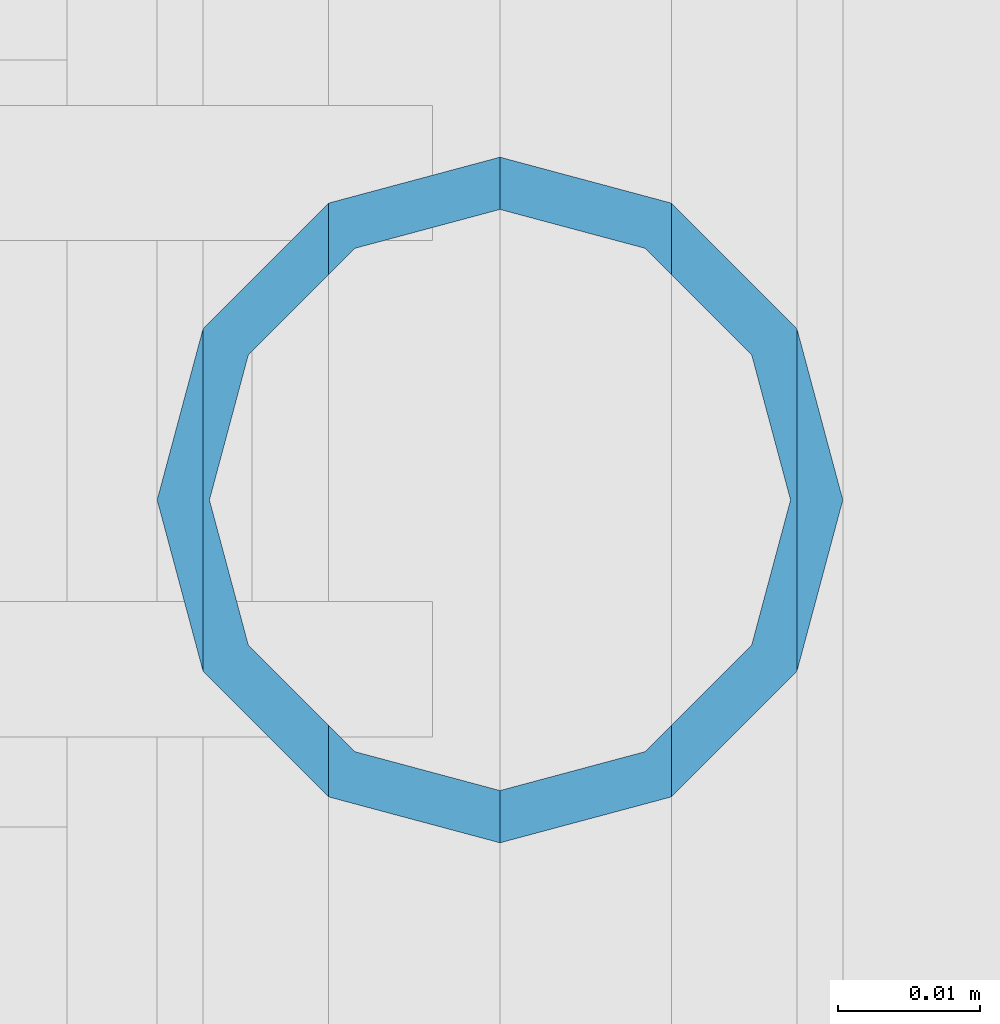
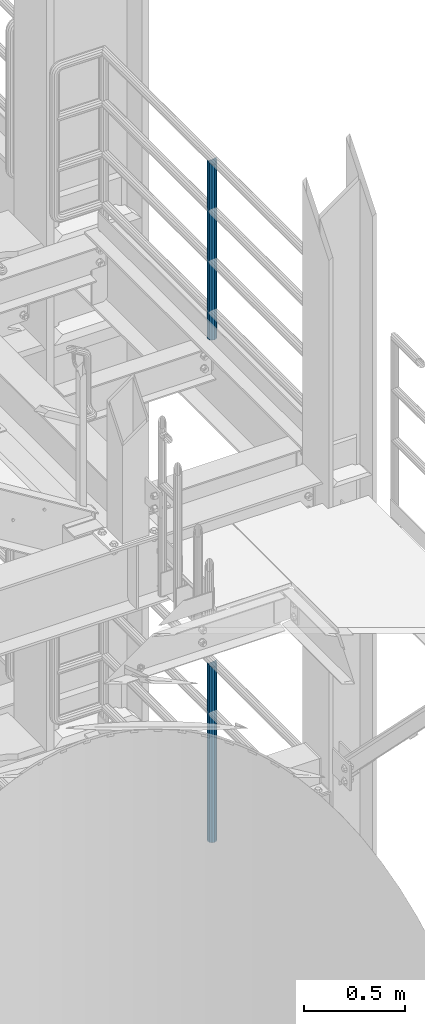
# One storey, part 660 of 1876: 2 columns, 2 elements without a shape of their own.
"""IFC2X3 building model written with IfcOpenShell, lengths in millimetres."""

from ifc_helpers import new_model, si_unit, frame, origin_with_axes, place, context, subcontext, project, spatial, faceted_brep, material, type_object, element, aggregate, save


model = new_model("IFC2X3")

# Units and contexts
model_context = context("Model", 3, precision=1e-05, world=origin_with_axes())
body_context = subcontext(model_context, "Body", "Model", "MODEL_VIEW")
ifc_project = project(units=[si_unit("LENGTHUNIT", "METRE", prefix="MILLI"), si_unit("AREAUNIT", "SQUARE_METRE"), si_unit("VOLUMEUNIT", "CUBIC_METRE"), si_unit("MASSUNIT", "GRAM", prefix="KILO"), si_unit("TIMEUNIT", "SECOND"), si_unit("PLANEANGLEUNIT", "RADIAN"), si_unit("SOLIDANGLEUNIT", "STERADIAN"), si_unit("THERMODYNAMICTEMPERATUREUNIT", "DEGREE_CELSIUS"), si_unit("LUMINOUSINTENSITYUNIT", "LUMEN")], contexts=[model_context])

# Site, building, storey
site_placement = place(None, origin_with_axes())
site = spatial("IfcSite", under=ifc_project, at=site_placement, CompositionType="ELEMENT")
building_placement = place(site_placement, origin_with_axes())
building = spatial("IfcBuilding", under=site, at=building_placement, Name="Undefined", CompositionType="ELEMENT")
storey_placement = place(building_placement, origin_with_axes())
storey = spatial("IfcBuildingStorey", under=building, at=storey_placement, Name="Undefined", CompositionType="ELEMENT", Elevation=0.0)

# Assembly, column
assembly_1_placement = place(storey_placement, origin_with_axes())
assembly_1 = element("IfcElementAssembly", 1, at=assembly_1_placement, inside=storey, Name="RAIL", AssemblyPlace="NOTDEFINED", PredefinedType="RIGID_FRAME")
ifc_material = material()
column_type = type_object("IfcColumnType", Name="PIPE1-1/2SCH40", PredefinedType="NOTDEFINED")
column_1_placement = place(assembly_1_placement, frame((7620.00000000001, -5857.08125, 8153.4), z_axis=(0.0, 1.0, 0.0), x_axis=(0.0, 0.0, 1.0)))
column_1 = element("IfcColumn", 2, at=column_1_placement, type_object=column_type, material=ifc_material, Name="POST", ObjectType="PIPE1-1/2SCH40", context=body_context, shape_type="Brep", body=[
    faceted_brep([(1055.42780700668, -12.0650000000001, 20.8971929933186), (1055.42780700668, -12.0650000000001, 15.8661214311805), (1054.93437856882, -10.2235000000001, 17.7076214311801), (1052.195, 0.0, 20.4470000000001), (1052.195, 0.0, 24.1300000000001), (1054.93437856882, 10.2235000000001, 17.7076214311801), (1055.42780700668, 12.0650000000001, 15.8661214311805), (1055.42780700668, 12.0650000000001, 20.8971929933186), (1076.325, 24.1300000000001, 0.0), (1064.26, 20.8971929933184, 12.0649999999996), (1064.25999999999, 20.8971929933186, -12.0649999999996), (1061.07042843786, 17.7076214311803, 10.2235000000001), (1063.80980700668, 20.4469999999999, 0.0), (1061.07042843786, 17.7076214311803, -10.2235000000001), (1055.42780700668, 12.0650000000001, -15.8661214311805), (1055.42780700667, 12.0649999999996, -20.8971929933186), (1054.93437856882, 10.2235000000001, -17.7076214311801), (1052.195, 0.0, -20.4470000000001), (1052.19499999999, 0.0, -24.1300000000001), (1055.42780700668, -12.0650000000001, -15.8661214311805), (1055.42780700667, -12.0649999999996, -20.8971929933186), (1054.93437856882, -10.2235000000001, -17.7076214311801), (1076.325, -24.1300000000001, 0.0), (1064.25999999999, -20.8971929933186, -12.0649999999996), (1064.26, -20.8971929933184, 12.0649999999996), (1061.07042843786, -17.7076214311803, -10.2235000000001), (1063.80980700668, -20.4469999999999, 0.0), (1061.07042843786, -17.7076214311803, 10.2235000000001), (0.0, -20.8971929933184, -12.0649999999996), (0.0, -12.0650000000001, -20.8971929933186), (-1.45519152283669e-11, 0.0, -24.130000000001), (0.0, 12.0650000000001, -20.8971929933186), (0.0, 20.8971929933184, -12.0649999999996), (0.0, 24.1299999999992, 0.0), (0.0, 20.8971929933184, 12.0649999999996), (0.0, 12.0650000000001, 20.8971929933186), (-1.45519152283669e-11, 0.0, 24.130000000001), (0.0, -12.0650000000001, 20.8971929933186), (0.0, -20.8971929933184, 12.0649999999996), (0.0, -24.1299999999992, 0.0), (0.0, -17.7076214311803, -10.2235000000001), (0.0, -10.2235000000001, -17.7076214311801), (-1.45519152283669e-11, 0.0, -20.4470000000001), (0.0, 10.2235000000001, -17.7076214311801), (0.0, 17.7076214311803, -10.2235000000001), (0.0, 20.4469999999999, 0.0), (0.0, 17.7076214311803, 10.2235000000001), (0.0, 10.2235000000001, 17.7076214311801), (-1.45519152283669e-11, 0.0, 20.4470000000001), (0.0, -10.2235000000001, 17.7076214311801), (0.0, -17.7076214311803, 10.2235000000001), (0.0, -20.4469999999999, 0.0)], [[[0, 1, 2, 3, 4]], [[4, 3, 5, 6, 7]], [[8, 9, 10]], [[7, 6, 11, 12, 13, 14, 15, 10, 9]], [[16, 17, 18, 15, 14]], [[19, 20, 18, 17, 21]], [[22, 23, 24]], [[24, 23, 20, 19, 25, 26, 27, 1, 0]], [[28, 29, 20, 23]], [[29, 30, 18, 20]], [[30, 31, 15, 18]], [[31, 32, 10, 15]], [[32, 33, 8, 10]], [[33, 34, 9, 8]], [[34, 35, 7, 9]], [[35, 36, 4, 7]], [[36, 37, 0, 4]], [[37, 38, 24, 0]], [[38, 39, 22, 24]], [[39, 28, 23, 22]], [[38, 37, 36, 35, 34, 33, 32, 31, 30, 29, 28, 39], [40, 41, 42, 43, 44, 45, 46, 47, 48, 49, 50, 51]], [[40, 51, 26, 25]], [[21, 41, 40, 25, 19]], [[42, 41, 21, 17]], [[43, 42, 17, 16]], [[44, 43, 16, 14, 13]], [[45, 44, 13, 12]], [[46, 45, 12, 11]], [[5, 47, 46, 11, 6]], [[48, 47, 5, 3]], [[49, 48, 3, 2]], [[50, 49, 2, 1, 27]], [[51, 50, 27, 26]]]),
])
aggregate(assembly_1, [column_1])

assembly_2_placement = place(storey_placement, origin_with_axes())
assembly_2 = element("IfcElementAssembly", 3, at=assembly_2_placement, inside=storey, Name="RAIL", AssemblyPlace="NOTDEFINED", PredefinedType="RIGID_FRAME")
column_2_placement = place(assembly_2_placement, frame((7620.00000000001, -5857.08125, 5130.80000110474), z_axis=(0.0, 1.0, 0.0), x_axis=(0.0, 0.0, 1.0)))
column_2 = element("IfcColumn", 4, at=column_2_placement, type_object=column_type, material=ifc_material, Name="POST", ObjectType="PIPE1-1/2SCH40", context=body_context, shape_type="Brep", body=[
    faceted_brep([(1055.42780700668, -12.0650000000001, 20.8971929933186), (1055.42780700668, -12.0650000000001, 15.8661214311805), (1054.93437856882, -10.2235000000001, 17.7076214311801), (1052.195, 0.0, 20.4470000000001), (1052.195, 0.0, 24.1300000000001), (1054.93437856882, 10.2235000000001, 17.7076214311801), (1055.42780700668, 12.0650000000001, 15.8661214311805), (1055.42780700668, 12.0650000000001, 20.8971929933186), (1076.325, 24.1300000000001, 0.0), (1064.26, 20.8971929933184, 12.0649999999996), (1064.25999999999, 20.8971929933186, -12.0649999999996), (1061.07042843786, 17.7076214311803, 10.2235000000001), (1063.80980700668, 20.4469999999999, 0.0), (1061.07042843786, 17.7076214311803, -10.2235000000001), (1055.42780700668, 12.0650000000001, -15.8661214311805), (1055.42780700667, 12.0649999999996, -20.8971929933186), (1054.93437856882, 10.2235000000001, -17.7076214311801), (1052.195, 0.0, -20.4470000000001), (1052.19499999999, 0.0, -24.1300000000001), (1055.42780700668, -12.0650000000001, -15.8661214311805), (1055.42780700667, -12.0649999999996, -20.8971929933186), (1054.93437856882, -10.2235000000001, -17.7076214311801), (1076.325, -24.1300000000001, 0.0), (1064.25999999999, -20.8971929933186, -12.0649999999996), (1064.26, -20.8971929933184, 12.0649999999996), (1061.07042843786, -17.7076214311803, -10.2235000000001), (1063.80980700668, -20.4469999999999, 0.0), (1061.07042843786, -17.7076214311803, 10.2235000000001), (0.0, -20.8971929933184, -12.0649999999996), (0.0, -12.0650000000001, -20.8971929933186), (-1.45519152283669e-11, 0.0, -24.130000000001), (0.0, 12.0650000000001, -20.8971929933186), (0.0, 20.8971929933184, -12.0649999999996), (0.0, 24.1299999999992, 0.0), (0.0, 20.8971929933184, 12.0649999999996), (0.0, 12.0650000000001, 20.8971929933186), (-1.45519152283669e-11, 0.0, 24.130000000001), (0.0, -12.0650000000001, 20.8971929933186), (0.0, -20.8971929933184, 12.0649999999996), (0.0, -24.1299999999992, 0.0), (0.0, -17.7076214311803, -10.2235000000001), (0.0, -10.2235000000001, -17.7076214311801), (-1.45519152283669e-11, 0.0, -20.4470000000001), (0.0, 10.2235000000001, -17.7076214311801), (0.0, 17.7076214311803, -10.2235000000001), (0.0, 20.4469999999999, 0.0), (0.0, 17.7076214311803, 10.2235000000001), (0.0, 10.2235000000001, 17.7076214311801), (-1.45519152283669e-11, 0.0, 20.4470000000001), (0.0, -10.2235000000001, 17.7076214311801), (0.0, -17.7076214311803, 10.2235000000001), (0.0, -20.4469999999999, 0.0)], [[[0, 1, 2, 3, 4]], [[4, 3, 5, 6, 7]], [[8, 9, 10]], [[7, 6, 11, 12, 13, 14, 15, 10, 9]], [[16, 17, 18, 15, 14]], [[19, 20, 18, 17, 21]], [[22, 23, 24]], [[24, 23, 20, 19, 25, 26, 27, 1, 0]], [[28, 29, 20, 23]], [[29, 30, 18, 20]], [[30, 31, 15, 18]], [[31, 32, 10, 15]], [[32, 33, 8, 10]], [[33, 34, 9, 8]], [[34, 35, 7, 9]], [[35, 36, 4, 7]], [[36, 37, 0, 4]], [[37, 38, 24, 0]], [[38, 39, 22, 24]], [[39, 28, 23, 22]], [[38, 37, 36, 35, 34, 33, 32, 31, 30, 29, 28, 39], [40, 41, 42, 43, 44, 45, 46, 47, 48, 49, 50, 51]], [[40, 51, 26, 25]], [[21, 41, 40, 25, 19]], [[42, 41, 21, 17]], [[43, 42, 17, 16]], [[44, 43, 16, 14, 13]], [[45, 44, 13, 12]], [[46, 45, 12, 11]], [[5, 47, 46, 11, 6]], [[48, 47, 5, 3]], [[49, 48, 3, 2]], [[50, 49, 2, 1, 27]], [[51, 50, 27, 26]]]),
])
aggregate(assembly_2, [column_2])

save(model, "model.ifc")
